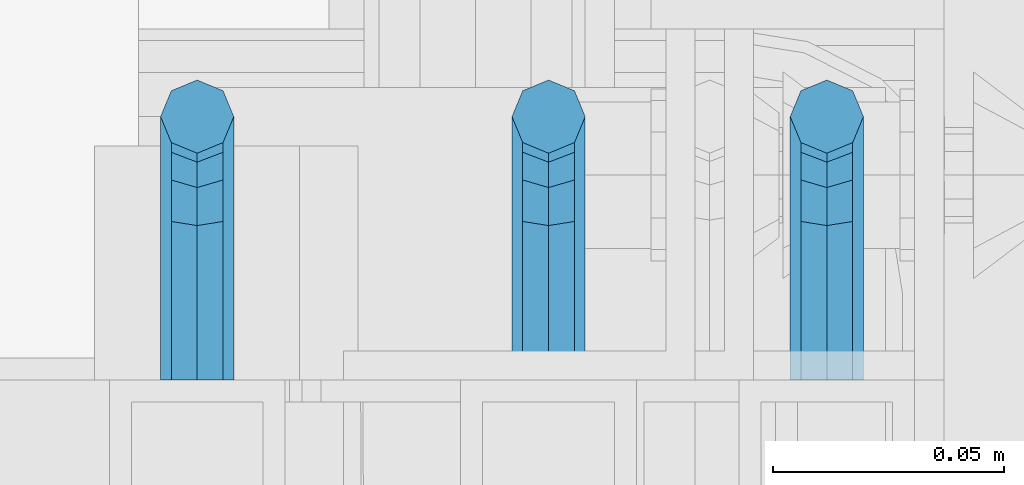
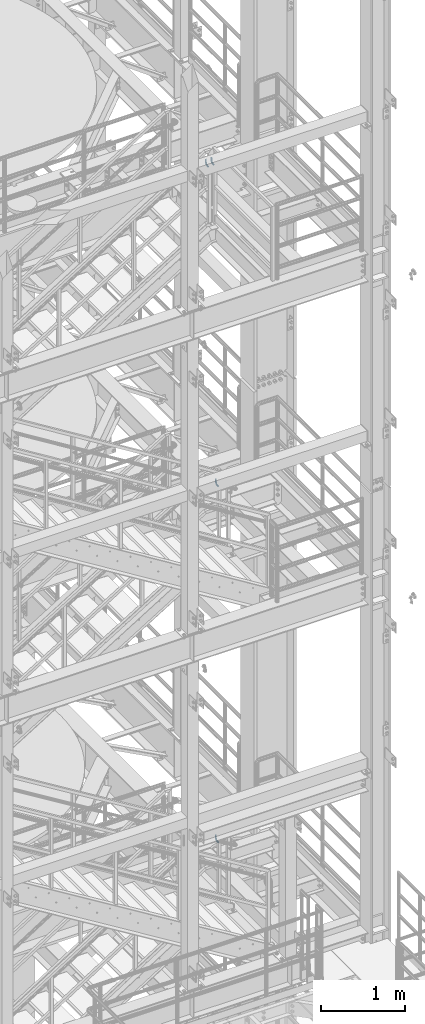
# One storey, part 1196 of 1876: 4 beams, 3 elements without a shape of their own.
"""IFC2X3 building model written with IfcOpenShell, lengths in millimetres."""

from ifc_helpers import new_model, si_unit, frame, origin_with_axes, place, context, subcontext, project, spatial, faceted_brep, material, type_object, element, aggregate, save


model = new_model("IFC2X3")

# Units and contexts
model_context = context("Model", 3, precision=1e-05, world=origin_with_axes())
body_context = subcontext(model_context, "Body", "Model", "MODEL_VIEW")
ifc_project = project(units=[si_unit("LENGTHUNIT", "METRE", prefix="MILLI"), si_unit("AREAUNIT", "SQUARE_METRE"), si_unit("VOLUMEUNIT", "CUBIC_METRE"), si_unit("MASSUNIT", "GRAM", prefix="KILO"), si_unit("TIMEUNIT", "SECOND"), si_unit("PLANEANGLEUNIT", "RADIAN"), si_unit("SOLIDANGLEUNIT", "STERADIAN"), si_unit("THERMODYNAMICTEMPERATUREUNIT", "DEGREE_CELSIUS"), si_unit("LUMINOUSINTENSITYUNIT", "LUMEN")], contexts=[model_context])

# Site, building, storey
site_placement = place(None, origin_with_axes())
site = spatial("IfcSite", under=ifc_project, at=site_placement, CompositionType="ELEMENT")
building_placement = place(site_placement, origin_with_axes())
building = spatial("IfcBuilding", under=site, at=building_placement, Name="Undefined", CompositionType="ELEMENT")
storey_placement = place(building_placement, origin_with_axes())
storey = spatial("IfcBuildingStorey", under=building, at=storey_placement, Name="Undefined", CompositionType="ELEMENT", Elevation=0.0)

# Assembly, beams
assembly_1_placement = place(storey_placement, origin_with_axes())
assembly_1 = element("IfcElementAssembly", 1, at=assembly_1_placement, inside=storey, Name="RAIL", AssemblyPlace="NOTDEFINED", PredefinedType="RIGID_FRAME")
ifc_material = material(Name="STEEL/A36")
beam_type = type_object("IfcBeamType", PredefinedType="NOTDEFINED")
beam_1_placement = place(assembly_1_placement, frame((6213.47499647628, -5715.00000114554, 18808.699999999), z_axis=(1.0, 0.0, 0.0), x_axis=(0.0, 1.0, 0.0)))
beam_1 = element("IfcBeam", 2, at=beam_1_placement, type_object=beam_type, material=ifc_material, Name="BRACKET", context=body_context, shape_type="Brep", body=[
    faceted_brep([(0.0, -7.9375, 0.0), (0.0, -5.61266007566822, -5.61266007566883), (23.8125, -5.61266007566883, -5.61266007566792), (23.8125, -7.9375, 0.0), (0.0, 0.0, -7.9375), (23.8125, 0.0, -7.9375), (0.0, 5.61266007566822, -5.61266007566883), (23.8125, 5.61266007566883, -5.61266007566792), (0.0, 7.9375, 0.0), (23.8125, 7.9375, 0.0), (0.0, 5.61266007566822, 5.61266007566883), (23.8125, 5.61266007566883, 5.61266007566792), (0.0, 0.0, 7.9375), (23.8125, 0.0, 7.9375), (0.0, -5.61266007566822, 5.61266007566883), (23.8125, -5.61266007566883, 5.61266007566792), (39.6077592547981, -4.79562758825341, 0.0), (38.7180815328556, -2.64775556579843, 5.61266007566792), (36.5702095103998, 2.53766620105671, 7.9375), (34.4223374879448, 7.72308796790821, 5.61266007566792), (33.5326597660023, 9.87095999036319, 0.0), (34.4223374879448, 7.72308796790821, -5.61266007566792), (36.5702095103998, 2.53766620105671, -7.9375), (38.7180815328556, -2.64775556579843, -5.61266007566792), (51.3544233967659, 5.79557812911298, -5.61266007566792), (52.9983334724348, 4.15166805344415, 0.0), (47.3856733967659, 9.76432812911298, -7.9375), (43.4169233967659, 13.733078129113, -5.61266007566792), (41.773013321098, 15.3769882047818, 0.0), (43.4169233967659, 13.733078129113, 5.61266007566792), (47.3856733967659, 9.76432812911298, 7.9375), (51.3544233967659, 5.79557812911298, 5.61266007566792), (59.7977570916764, 18.4319199930251, -5.61266007566792), (61.9456291141314, 17.5422422710835, 0.0), (54.6123353248231, 20.5797920154801, -7.9375), (49.4269135579698, 22.727664037935, -5.61266007566792), (47.2790415355148, 23.6173417598766, 0.0), (49.4269135579698, 22.727664037935, 5.61266007566792), (54.6123353248231, 20.5797920154801, 7.9375), (59.7977570916764, 18.4319199930251, 5.61266007566792), (62.7626616015468, 33.3375015258789, -5.61266007566792), (65.0875015258789, 33.3375015258789, 0.0), (57.1500015258789, 33.3375015258789, -7.9375), (51.5373414502101, 33.3375015258789, -5.61266007566792), (49.2125015258789, 33.3375015258789, 0.0), (51.5373414502101, 33.3375015258789, 5.61266007566792), (57.1500015258789, 33.3375015258789, 7.9375), (62.7626616015468, 33.3375015258789, 5.61266007566792), (62.7626616015468, 69.8499984741211, -5.61266007566792), (65.0875015258789, 69.8499984741211, 0.0), (57.1500015258789, 69.8499984741211, -7.9375), (51.537341450211, 69.8499984741211, -5.61266007566792), (49.2125015258789, 69.8499984741211, 0.0), (51.537341450211, 69.8499984741211, 5.61266007566792), (57.1500015258789, 69.8499984741211, 7.9375), (62.7626616015468, 69.8499984741211, 5.61266007566792)], [[[0, 1, 2, 3]], [[1, 4, 5, 2]], [[4, 6, 7, 5]], [[6, 8, 9, 7]], [[8, 10, 11, 9]], [[10, 12, 13, 11]], [[12, 14, 15, 13]], [[14, 0, 3, 15]], [[14, 12, 10, 8, 6, 4, 1, 0]], [[15, 3, 16, 17]], [[13, 15, 17, 18]], [[11, 13, 18, 19]], [[9, 11, 19, 20]], [[7, 9, 20, 21]], [[5, 7, 21, 22]], [[2, 5, 22, 23]], [[3, 2, 23, 16]], [[23, 24, 25, 16]], [[22, 26, 24, 23]], [[21, 27, 26, 22]], [[20, 28, 27, 21]], [[19, 29, 28, 20]], [[18, 30, 29, 19]], [[17, 31, 30, 18]], [[16, 25, 31, 17]], [[24, 32, 33, 25]], [[26, 34, 32, 24]], [[27, 35, 34, 26]], [[28, 36, 35, 27]], [[29, 37, 36, 28]], [[30, 38, 37, 29]], [[31, 39, 38, 30]], [[25, 33, 39, 31]], [[32, 40, 41, 33]], [[34, 42, 40, 32]], [[35, 43, 42, 34]], [[36, 44, 43, 35]], [[37, 45, 44, 36]], [[38, 46, 45, 37]], [[39, 47, 46, 38]], [[33, 41, 47, 39]], [[41, 40, 48, 49]], [[40, 42, 50, 48]], [[42, 43, 51, 50]], [[43, 44, 52, 51]], [[44, 45, 53, 52]], [[45, 46, 54, 53]], [[46, 47, 55, 54]], [[47, 41, 49, 55]], [[50, 51, 52, 53, 54, 55, 49, 48]]]),
])
beam_2_placement = place(assembly_1_placement, frame((6137.27499791815, -5715.00000114554, 18808.699999999), z_axis=(1.0, 0.0, 0.0), x_axis=(0.0, 1.0, 0.0)))
beam_2 = element("IfcBeam", 3, at=beam_2_placement, type_object=beam_type, material=ifc_material, Name="BRACKET", context=body_context, shape_type="Brep", body=[
    faceted_brep([(0.0, -7.9375, 0.0), (0.0, -5.61266007566822, -5.61266007566883), (23.8125, -5.61266007566883, -5.61266007566792), (23.8125, -7.9375, 0.0), (0.0, 0.0, -7.9375), (23.8125, 0.0, -7.9375), (0.0, 5.61266007566822, -5.61266007566883), (23.8125, 5.61266007566883, -5.61266007566792), (0.0, 7.9375, 0.0), (23.8125, 7.9375, 0.0), (0.0, 5.61266007566822, 5.61266007566883), (23.8125, 5.61266007566883, 5.61266007566792), (0.0, 0.0, 7.9375), (23.8125, 0.0, 7.9375), (0.0, -5.61266007566822, 5.61266007566883), (23.8125, -5.61266007566883, 5.61266007566792), (39.6077592547981, -4.79562758825341, 0.0), (38.7180815328556, -2.64775556579843, 5.61266007566792), (36.5702095103998, 2.53766620105671, 7.9375), (34.4223374879448, 7.72308796790821, 5.61266007566792), (33.5326597660023, 9.87095999036319, 0.0), (34.4223374879448, 7.72308796790821, -5.61266007566792), (36.5702095103998, 2.53766620105671, -7.9375), (38.7180815328556, -2.64775556579843, -5.61266007566792), (51.3544233967659, 5.79557812911298, -5.61266007566792), (52.9983334724348, 4.15166805344415, 0.0), (47.3856733967659, 9.76432812911298, -7.9375), (43.4169233967659, 13.733078129113, -5.61266007566792), (41.773013321098, 15.3769882047818, 0.0), (43.4169233967659, 13.733078129113, 5.61266007566792), (47.3856733967659, 9.76432812911298, 7.9375), (51.3544233967659, 5.79557812911298, 5.61266007566792), (59.7977570916764, 18.4319199930251, -5.61266007566792), (61.9456291141314, 17.5422422710835, 0.0), (54.6123353248231, 20.5797920154801, -7.9375), (49.4269135579698, 22.727664037935, -5.61266007566792), (47.2790415355148, 23.6173417598766, 0.0), (49.4269135579698, 22.727664037935, 5.61266007566792), (54.6123353248231, 20.5797920154801, 7.9375), (59.7977570916764, 18.4319199930251, 5.61266007566792), (62.7626616015468, 33.3375015258789, -5.61266007566792), (65.0875015258789, 33.3375015258789, 0.0), (57.1500015258789, 33.3375015258789, -7.9375), (51.5373414502101, 33.3375015258789, -5.61266007566792), (49.2125015258789, 33.3375015258789, 0.0), (51.5373414502101, 33.3375015258789, 5.61266007566792), (57.1500015258789, 33.3375015258789, 7.9375), (62.7626616015468, 33.3375015258789, 5.61266007566792), (62.7626616015468, 69.8499984741211, -5.61266007566792), (65.0875015258789, 69.8499984741211, 0.0), (57.1500015258789, 69.8499984741211, -7.9375), (51.537341450211, 69.8499984741211, -5.61266007566792), (49.2125015258789, 69.8499984741211, 0.0), (51.537341450211, 69.8499984741211, 5.61266007566792), (57.1500015258789, 69.8499984741211, 7.9375), (62.7626616015468, 69.8499984741211, 5.61266007566792)], [[[0, 1, 2, 3]], [[1, 4, 5, 2]], [[4, 6, 7, 5]], [[6, 8, 9, 7]], [[8, 10, 11, 9]], [[10, 12, 13, 11]], [[12, 14, 15, 13]], [[14, 0, 3, 15]], [[14, 12, 10, 8, 6, 4, 1, 0]], [[15, 3, 16, 17]], [[13, 15, 17, 18]], [[11, 13, 18, 19]], [[9, 11, 19, 20]], [[7, 9, 20, 21]], [[5, 7, 21, 22]], [[2, 5, 22, 23]], [[3, 2, 23, 16]], [[23, 24, 25, 16]], [[22, 26, 24, 23]], [[21, 27, 26, 22]], [[20, 28, 27, 21]], [[19, 29, 28, 20]], [[18, 30, 29, 19]], [[17, 31, 30, 18]], [[16, 25, 31, 17]], [[24, 32, 33, 25]], [[26, 34, 32, 24]], [[27, 35, 34, 26]], [[28, 36, 35, 27]], [[29, 37, 36, 28]], [[30, 38, 37, 29]], [[31, 39, 38, 30]], [[25, 33, 39, 31]], [[32, 40, 41, 33]], [[34, 42, 40, 32]], [[35, 43, 42, 34]], [[36, 44, 43, 35]], [[37, 45, 44, 36]], [[38, 46, 45, 37]], [[39, 47, 46, 38]], [[33, 41, 47, 39]], [[41, 40, 48, 49]], [[40, 42, 50, 48]], [[42, 43, 51, 50]], [[43, 44, 52, 51]], [[44, 45, 53, 52]], [[45, 46, 54, 53]], [[46, 47, 55, 54]], [[47, 41, 49, 55]], [[50, 51, 52, 53, 54, 55, 49, 48]]]),
])
aggregate(assembly_1, [beam_1, beam_2])

# Assembly, beam
assembly_2_placement = place(storey_placement, origin_with_axes())
assembly_2 = element("IfcElementAssembly", 4, at=assembly_2_placement, inside=storey, Name="RAIL", AssemblyPlace="NOTDEFINED", PredefinedType="RIGID_FRAME")
beam_3_placement = place(assembly_2_placement, frame((6273.80000001181, -5715.00000114554, 14135.1), z_axis=(1.0, 0.0, 0.0), x_axis=(0.0, 1.0, 0.0)))
beam_3 = element("IfcBeam", 5, at=beam_3_placement, type_object=beam_type, material=ifc_material, Name="BRACKET", context=body_context, shape_type="Brep", body=[
    faceted_brep([(0.0, -7.9375, 0.0), (0.0, -5.61266007566822, -5.61266007566883), (23.8125, -5.61266007566883, -5.61266007566792), (23.8125, -7.9375, 0.0), (0.0, 0.0, -7.9375), (23.8125, 0.0, -7.9375), (0.0, 5.61266007566822, -5.61266007566883), (23.8125, 5.61266007566883, -5.61266007566792), (0.0, 7.9375, 0.0), (23.8125, 7.9375, 0.0), (0.0, 5.61266007566822, 5.61266007566883), (23.8125, 5.61266007566883, 5.61266007566792), (0.0, 0.0, 7.9375), (23.8125, 0.0, 7.9375), (0.0, -5.61266007566822, 5.61266007566883), (23.8125, -5.61266007566883, 5.61266007566792), (39.6077592547981, -4.79562758825341, 0.0), (38.7180815328556, -2.64775556579843, 5.61266007566792), (36.5702095103998, 2.53766620105671, 7.9375), (34.4223374879448, 7.72308796790821, 5.61266007566792), (33.5326597660023, 9.87095999036319, 0.0), (34.4223374879448, 7.72308796790821, -5.61266007566792), (36.5702095103998, 2.53766620105671, -7.9375), (38.7180815328556, -2.64775556579843, -5.61266007566792), (51.3544233967659, 5.79557812911298, -5.61266007566792), (52.9983334724348, 4.15166805344415, 0.0), (47.3856733967659, 9.76432812911298, -7.9375), (43.4169233967659, 13.733078129113, -5.61266007566792), (41.773013321098, 15.3769882047818, 0.0), (43.4169233967659, 13.733078129113, 5.61266007566792), (47.3856733967659, 9.76432812911298, 7.9375), (51.3544233967659, 5.79557812911298, 5.61266007566792), (59.7977570916764, 18.4319199930251, -5.61266007566792), (61.9456291141314, 17.5422422710835, 0.0), (54.6123353248231, 20.5797920154801, -7.9375), (49.4269135579698, 22.727664037935, -5.61266007566792), (47.2790415355148, 23.6173417598766, 0.0), (49.4269135579698, 22.727664037935, 5.61266007566792), (54.6123353248231, 20.5797920154801, 7.9375), (59.7977570916764, 18.4319199930251, 5.61266007566792), (62.7626616015468, 33.3375015258789, -5.61266007566792), (65.0875015258789, 33.3375015258789, 0.0), (57.1500015258789, 33.3375015258789, -7.9375), (51.5373414502101, 33.3375015258789, -5.61266007566792), (49.2125015258789, 33.3375015258789, 0.0), (51.5373414502101, 33.3375015258789, 5.61266007566792), (57.1500015258789, 33.3375015258789, 7.9375), (62.7626616015468, 33.3375015258789, 5.61266007566792), (62.7626616015468, 69.8499984741211, -5.61266007566792), (65.0875015258789, 69.8499984741211, 0.0), (57.1500015258789, 69.8499984741211, -7.9375), (51.537341450211, 69.8499984741211, -5.61266007566792), (49.2125015258789, 69.8499984741211, 0.0), (51.537341450211, 69.8499984741211, 5.61266007566792), (57.1500015258789, 69.8499984741211, 7.9375), (62.7626616015468, 69.8499984741211, 5.61266007566792)], [[[0, 1, 2, 3]], [[1, 4, 5, 2]], [[4, 6, 7, 5]], [[6, 8, 9, 7]], [[8, 10, 11, 9]], [[10, 12, 13, 11]], [[12, 14, 15, 13]], [[14, 0, 3, 15]], [[14, 12, 10, 8, 6, 4, 1, 0]], [[15, 3, 16, 17]], [[13, 15, 17, 18]], [[11, 13, 18, 19]], [[9, 11, 19, 20]], [[7, 9, 20, 21]], [[5, 7, 21, 22]], [[2, 5, 22, 23]], [[3, 2, 23, 16]], [[23, 24, 25, 16]], [[22, 26, 24, 23]], [[21, 27, 26, 22]], [[20, 28, 27, 21]], [[19, 29, 28, 20]], [[18, 30, 29, 19]], [[17, 31, 30, 18]], [[16, 25, 31, 17]], [[24, 32, 33, 25]], [[26, 34, 32, 24]], [[27, 35, 34, 26]], [[28, 36, 35, 27]], [[29, 37, 36, 28]], [[30, 38, 37, 29]], [[31, 39, 38, 30]], [[25, 33, 39, 31]], [[32, 40, 41, 33]], [[34, 42, 40, 32]], [[35, 43, 42, 34]], [[36, 44, 43, 35]], [[37, 45, 44, 36]], [[38, 46, 45, 37]], [[39, 47, 46, 38]], [[33, 41, 47, 39]], [[41, 40, 48, 49]], [[40, 42, 50, 48]], [[42, 43, 51, 50]], [[43, 44, 52, 51]], [[44, 45, 53, 52]], [[45, 46, 54, 53]], [[46, 47, 55, 54]], [[47, 41, 49, 55]], [[50, 51, 52, 53, 54, 55, 49, 48]]]),
])
aggregate(assembly_2, [beam_3])

assembly_3_placement = place(storey_placement, origin_with_axes())
assembly_3 = element("IfcElementAssembly", 6, at=assembly_3_placement, inside=storey, Name="RAIL", AssemblyPlace="NOTDEFINED", PredefinedType="RIGID_FRAME")
beam_4_placement = place(assembly_3_placement, frame((6273.79999407709, -5715.00000114554, 8978.9), z_axis=(1.0, 0.0, 0.0), x_axis=(0.0, 1.0, 0.0)))
beam_4 = element("IfcBeam", 7, at=beam_4_placement, type_object=beam_type, material=ifc_material, Name="BRACKET", context=body_context, shape_type="Brep", body=[
    faceted_brep([(0.0, -7.9375, 0.0), (0.0, -5.61266007566822, -5.61266007566883), (23.8125, -5.61266007566883, -5.61266007566792), (23.8125, -7.9375, 0.0), (0.0, 0.0, -7.9375), (23.8125, 0.0, -7.9375), (0.0, 5.61266007566822, -5.61266007566883), (23.8125, 5.61266007566883, -5.61266007566792), (0.0, 7.9375, 0.0), (23.8125, 7.9375, 0.0), (0.0, 5.61266007566822, 5.61266007566883), (23.8125, 5.61266007566883, 5.61266007566792), (0.0, 0.0, 7.9375), (23.8125, 0.0, 7.9375), (0.0, -5.61266007566822, 5.61266007566883), (23.8125, -5.61266007566883, 5.61266007566792), (39.6077592547981, -4.79562758825341, 0.0), (38.7180815328556, -2.64775556579843, 5.61266007566792), (36.5702095103998, 2.53766620105671, 7.9375), (34.4223374879448, 7.72308796790821, 5.61266007566792), (33.5326597660023, 9.87095999036319, 0.0), (34.4223374879448, 7.72308796790821, -5.61266007566792), (36.5702095103998, 2.53766620105671, -7.9375), (38.7180815328556, -2.64775556579843, -5.61266007566792), (51.3544233967659, 5.79557812911298, -5.61266007566792), (52.9983334724348, 4.15166805344415, 0.0), (47.3856733967659, 9.76432812911298, -7.9375), (43.4169233967659, 13.733078129113, -5.61266007566792), (41.773013321098, 15.3769882047818, 0.0), (43.4169233967659, 13.733078129113, 5.61266007566792), (47.3856733967659, 9.76432812911298, 7.9375), (51.3544233967659, 5.79557812911298, 5.61266007566792), (59.7977570916764, 18.4319199930251, -5.61266007566792), (61.9456291141314, 17.5422422710835, 0.0), (54.6123353248231, 20.5797920154801, -7.9375), (49.4269135579698, 22.727664037935, -5.61266007566792), (47.2790415355148, 23.6173417598766, 0.0), (49.4269135579698, 22.727664037935, 5.61266007566792), (54.6123353248231, 20.5797920154801, 7.9375), (59.7977570916764, 18.4319199930251, 5.61266007566792), (62.7626616015468, 33.3375015258789, -5.61266007566792), (65.0875015258789, 33.3375015258789, 0.0), (57.1500015258789, 33.3375015258789, -7.9375), (51.5373414502101, 33.3375015258789, -5.61266007566792), (49.2125015258789, 33.3375015258789, 0.0), (51.5373414502101, 33.3375015258789, 5.61266007566792), (57.1500015258789, 33.3375015258789, 7.9375), (62.7626616015468, 33.3375015258789, 5.61266007566792), (62.7626616015468, 69.8499984741211, -5.61266007566792), (65.0875015258789, 69.8499984741211, 0.0), (57.1500015258789, 69.8499984741211, -7.9375), (51.537341450211, 69.8499984741211, -5.61266007566792), (49.2125015258789, 69.8499984741211, 0.0), (51.537341450211, 69.8499984741211, 5.61266007566792), (57.1500015258789, 69.8499984741211, 7.9375), (62.7626616015468, 69.8499984741211, 5.61266007566792)], [[[0, 1, 2, 3]], [[1, 4, 5, 2]], [[4, 6, 7, 5]], [[6, 8, 9, 7]], [[8, 10, 11, 9]], [[10, 12, 13, 11]], [[12, 14, 15, 13]], [[14, 0, 3, 15]], [[14, 12, 10, 8, 6, 4, 1, 0]], [[15, 3, 16, 17]], [[13, 15, 17, 18]], [[11, 13, 18, 19]], [[9, 11, 19, 20]], [[7, 9, 20, 21]], [[5, 7, 21, 22]], [[2, 5, 22, 23]], [[3, 2, 23, 16]], [[23, 24, 25, 16]], [[22, 26, 24, 23]], [[21, 27, 26, 22]], [[20, 28, 27, 21]], [[19, 29, 28, 20]], [[18, 30, 29, 19]], [[17, 31, 30, 18]], [[16, 25, 31, 17]], [[24, 32, 33, 25]], [[26, 34, 32, 24]], [[27, 35, 34, 26]], [[28, 36, 35, 27]], [[29, 37, 36, 28]], [[30, 38, 37, 29]], [[31, 39, 38, 30]], [[25, 33, 39, 31]], [[32, 40, 41, 33]], [[34, 42, 40, 32]], [[35, 43, 42, 34]], [[36, 44, 43, 35]], [[37, 45, 44, 36]], [[38, 46, 45, 37]], [[39, 47, 46, 38]], [[33, 41, 47, 39]], [[41, 40, 48, 49]], [[40, 42, 50, 48]], [[42, 43, 51, 50]], [[43, 44, 52, 51]], [[44, 45, 53, 52]], [[45, 46, 54, 53]], [[46, 47, 55, 54]], [[47, 41, 49, 55]], [[50, 51, 52, 53, 54, 55, 49, 48]]]),
])
aggregate(assembly_3, [beam_4])

save(model, "model.ifc")
